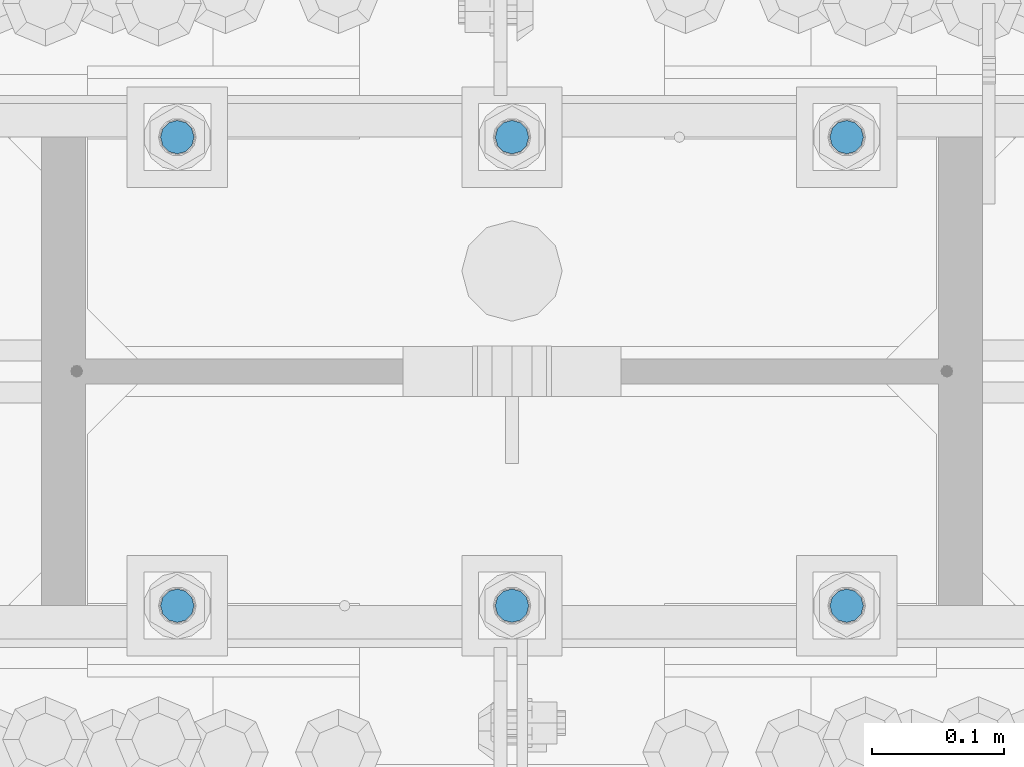
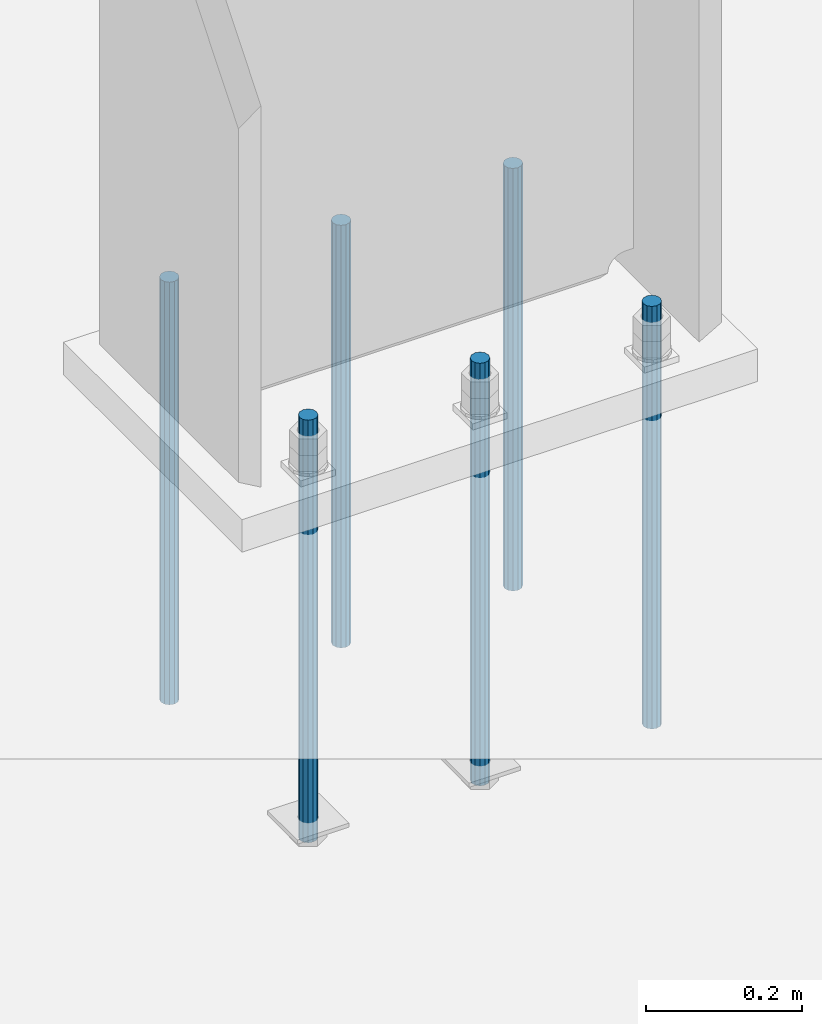
# One storey, part 952 of 1763: 6 columns, 1 element without a shape of its own.
"""IFC2X3 building model written with IfcOpenShell, lengths in millimetres."""

from ifc_helpers import new_model, si_unit, frame, origin_with_axes, place, context, subcontext, project, spatial, faceted_brep, material, type_object, element, aggregate, save


model = new_model("IFC2X3")

# Units and contexts
model_context = context("Model", 3, precision=1e-05, world=origin_with_axes())
body_context = subcontext(model_context, "Body", "Model", "MODEL_VIEW")
ifc_project = project(units=[si_unit("LENGTHUNIT", "METRE", prefix="MILLI"), si_unit("AREAUNIT", "SQUARE_METRE"), si_unit("VOLUMEUNIT", "CUBIC_METRE"), si_unit("MASSUNIT", "GRAM", prefix="KILO"), si_unit("TIMEUNIT", "SECOND"), si_unit("PLANEANGLEUNIT", "RADIAN"), si_unit("SOLIDANGLEUNIT", "STERADIAN"), si_unit("THERMODYNAMICTEMPERATUREUNIT", "DEGREE_CELSIUS"), si_unit("LUMINOUSINTENSITYUNIT", "LUMEN")], contexts=[model_context])

# Site, building, storey
site_placement = place(None, origin_with_axes())
site = spatial("IfcSite", under=ifc_project, at=site_placement, CompositionType="ELEMENT")
building_placement = place(site_placement, origin_with_axes())
building = spatial("IfcBuilding", under=site, at=building_placement, Name="Undefined", CompositionType="ELEMENT")
storey_placement = place(building_placement, origin_with_axes())
storey = spatial("IfcBuildingStorey", under=building, at=storey_placement, Name="Undefined", CompositionType="ELEMENT", Elevation=0.0)

# Assembly, columns
assembly_placement = place(storey_placement, origin_with_axes())
assembly = element("IfcElementAssembly", 1, at=assembly_placement, inside=storey, Name="TEMPLATE", AssemblyPlace="NOTDEFINED", PredefinedType="RIGID_FRAME")
ifc_material = material(Name="STEEL/F1554-55")
column_type = type_object("IfcColumnType", PredefinedType="NOTDEFINED")
column_1_placement = place(assembly_placement, frame((-72237.0372736984, 51943.0, -126.999999999999), z_axis=(1.0, 0.0, 0.0), x_axis=(0.0, 0.0, -1.0)))
column_1 = element("IfcColumn", 2, at=column_1_placement, type_object=column_type, material=ifc_material, Name="ALL THREADED ROD", context=body_context, shape_type="Brep", body=[
    faceted_brep([(0.0, -12.6999999999971, -1.81898940354586e-12), (0.0, -10.9985226280623, -6.35000000000582), (660.399, -10.9985226280623, -6.35000000000582), (660.399, -12.6999999999971, 0.0), (0.0, -6.34999999999854, -10.9985226280696), (660.399, -6.34999999999854, -10.9985226280696), (3.63797880709171e-12, 0.0, -12.6999998092651), (660.399, 0.0, -12.6999999999971), (0.0, 6.34999999999854, -10.9985226280696), (660.399, 6.34999999999854, -10.9985226280696), (0.0, 10.9985226280623, -6.35000000000582), (660.399, 10.9985226280623, -6.35000000000582), (0.0, 12.6999999999971, -1.81898940354586e-12), (660.399, 12.6999999999971, 0.0), (0.0, 10.9985226280623, 6.35000000000582), (660.399, 10.9985226280623, 6.35000000000582), (0.0, 6.34999999999854, 10.9985226280696), (660.399, 6.34999999999854, 10.9985226280696), (-3.63797880709171e-12, 0.0, 12.6999998092651), (660.399, 0.0, 12.6999999999971), (0.0, -6.34999999999854, 10.9985226280696), (660.399, -6.34999999999854, 10.9985226280696), (0.0, -10.9985226280623, 6.35000000000582), (660.399, -10.9985226280623, 6.35000000000582)], [[[0, 1, 2, 3]], [[1, 4, 5, 2]], [[4, 6, 7, 5]], [[6, 8, 9, 7]], [[8, 10, 11, 9]], [[10, 12, 13, 11]], [[12, 14, 15, 13]], [[14, 16, 17, 15]], [[16, 18, 19, 17]], [[18, 20, 21, 19]], [[20, 22, 23, 21]], [[22, 0, 3, 23]], [[5, 7, 9, 11, 13, 15, 17, 19, 21, 23, 3, 2]], [[22, 20, 18, 16, 14, 12, 10, 8, 6, 4, 1, 0]]]),
])
column_2_placement = place(assembly_placement, frame((-72237.0372736984, 52298.6, -126.999999999999), z_axis=(-1.0, 0.0, 0.0), x_axis=(0.0, 0.0, -1.0)))
column_2 = element("IfcColumn", 3, at=column_2_placement, type_object=column_type, material=ifc_material, Name="ALL THREADED ROD", context=body_context, shape_type="Brep", body=[
    faceted_brep([(0.0, -12.6999999999971, -1.81898940354586e-12), (0.0, -10.9985226280623, -6.35000000000582), (660.399, -10.9985226280623, -6.35000000000582), (660.399, -12.6999999999971, 0.0), (0.0, -6.34999999999854, -10.9985226280696), (660.399, -6.34999999999854, -10.9985226280696), (3.63797880709171e-12, 0.0, -12.6999998092651), (660.399, 0.0, -12.6999999999971), (0.0, 6.34999999999854, -10.9985226280696), (660.399, 6.34999999999854, -10.9985226280696), (0.0, 10.9985226280623, -6.35000000000582), (660.399, 10.9985226280623, -6.35000000000582), (0.0, 12.6999999999971, -1.81898940354586e-12), (660.399, 12.6999999999971, 0.0), (0.0, 10.9985226280623, 6.35000000000582), (660.399, 10.9985226280623, 6.35000000000582), (0.0, 6.34999999999854, 10.9985226280696), (660.399, 6.34999999999854, 10.9985226280696), (-3.63797880709171e-12, 0.0, 12.6999998092651), (660.399, 0.0, 12.6999999999971), (0.0, -6.34999999999854, 10.9985226280696), (660.399, -6.34999999999854, 10.9985226280696), (0.0, -10.9985226280623, 6.35000000000582), (660.399, -10.9985226280623, 6.35000000000582)], [[[0, 1, 2, 3]], [[1, 4, 5, 2]], [[4, 6, 7, 5]], [[6, 8, 9, 7]], [[8, 10, 11, 9]], [[10, 12, 13, 11]], [[12, 14, 15, 13]], [[14, 16, 17, 15]], [[16, 18, 19, 17]], [[18, 20, 21, 19]], [[20, 22, 23, 21]], [[22, 0, 3, 23]], [[5, 7, 9, 11, 13, 15, 17, 19, 21, 23, 3, 2]], [[22, 20, 18, 16, 14, 12, 10, 8, 6, 4, 1, 0]]]),
])
column_3_placement = place(assembly_placement, frame((-72491.0372736984, 51943.0, -126.999999999999), z_axis=(1.0, 0.0, 0.0), x_axis=(0.0, 0.0, -1.0)))
column_3 = element("IfcColumn", 4, at=column_3_placement, type_object=column_type, material=ifc_material, Name="ALL THREADED ROD", context=body_context, shape_type="Brep", body=[
    faceted_brep([(0.0, -12.6999999999971, -1.81898940354586e-12), (0.0, -10.9985226280623, -6.35000000000582), (660.399, -10.9985226280623, -6.35000000000582), (660.399, -12.6999999999971, 0.0), (0.0, -6.34999999999854, -10.9985226280696), (660.399, -6.34999999999854, -10.9985226280696), (3.63797880709171e-12, 0.0, -12.6999998092651), (660.399, 0.0, -12.6999999999971), (0.0, 6.34999999999854, -10.9985226280696), (660.399, 6.34999999999854, -10.9985226280696), (0.0, 10.9985226280623, -6.35000000000582), (660.399, 10.9985226280623, -6.35000000000582), (0.0, 12.6999999999971, -1.81898940354586e-12), (660.399, 12.6999999999971, 0.0), (0.0, 10.9985226280623, 6.35000000000582), (660.399, 10.9985226280623, 6.35000000000582), (0.0, 6.34999999999854, 10.9985226280696), (660.399, 6.34999999999854, 10.9985226280696), (-3.63797880709171e-12, 0.0, 12.6999998092651), (660.399, 0.0, 12.6999999999971), (0.0, -6.34999999999854, 10.9985226280696), (660.399, -6.34999999999854, 10.9985226280696), (0.0, -10.9985226280623, 6.35000000000582), (660.399, -10.9985226280623, 6.35000000000582)], [[[0, 1, 2, 3]], [[1, 4, 5, 2]], [[4, 6, 7, 5]], [[6, 8, 9, 7]], [[8, 10, 11, 9]], [[10, 12, 13, 11]], [[12, 14, 15, 13]], [[14, 16, 17, 15]], [[16, 18, 19, 17]], [[18, 20, 21, 19]], [[20, 22, 23, 21]], [[22, 0, 3, 23]], [[5, 7, 9, 11, 13, 15, 17, 19, 21, 23, 3, 2]], [[22, 20, 18, 16, 14, 12, 10, 8, 6, 4, 1, 0]]]),
])
column_4_placement = place(assembly_placement, frame((-72491.0372736984, 52298.6, -126.999999999999), z_axis=(-1.0, 0.0, 0.0), x_axis=(0.0, 0.0, -1.0)))
column_4 = element("IfcColumn", 5, at=column_4_placement, type_object=column_type, material=ifc_material, Name="ALL THREADED ROD", context=body_context, shape_type="Brep", body=[
    faceted_brep([(0.0, -12.6999999999971, -1.81898940354586e-12), (0.0, -10.9985226280623, -6.35000000000582), (660.399, -10.9985226280623, -6.35000000000582), (660.399, -12.6999999999971, 0.0), (0.0, -6.34999999999854, -10.9985226280696), (660.399, -6.34999999999854, -10.9985226280696), (3.63797880709171e-12, 0.0, -12.6999998092651), (660.399, 0.0, -12.6999999999971), (0.0, 6.34999999999854, -10.9985226280696), (660.399, 6.34999999999854, -10.9985226280696), (0.0, 10.9985226280623, -6.35000000000582), (660.399, 10.9985226280623, -6.35000000000582), (0.0, 12.6999999999971, -1.81898940354586e-12), (660.399, 12.6999999999971, 0.0), (0.0, 10.9985226280623, 6.35000000000582), (660.399, 10.9985226280623, 6.35000000000582), (0.0, 6.34999999999854, 10.9985226280696), (660.399, 6.34999999999854, 10.9985226280696), (-3.63797880709171e-12, 0.0, 12.6999998092651), (660.399, 0.0, 12.6999999999971), (0.0, -6.34999999999854, 10.9985226280696), (660.399, -6.34999999999854, 10.9985226280696), (0.0, -10.9985226280623, 6.35000000000582), (660.399, -10.9985226280623, 6.35000000000582)], [[[0, 1, 2, 3]], [[1, 4, 5, 2]], [[4, 6, 7, 5]], [[6, 8, 9, 7]], [[8, 10, 11, 9]], [[10, 12, 13, 11]], [[12, 14, 15, 13]], [[14, 16, 17, 15]], [[16, 18, 19, 17]], [[18, 20, 21, 19]], [[20, 22, 23, 21]], [[22, 0, 3, 23]], [[5, 7, 9, 11, 13, 15, 17, 19, 21, 23, 3, 2]], [[22, 20, 18, 16, 14, 12, 10, 8, 6, 4, 1, 0]]]),
])
column_5_placement = place(assembly_placement, frame((-72745.0372736984, 51943.0, -126.999999999999), z_axis=(1.0, 0.0, 0.0), x_axis=(0.0, 0.0, -1.0)))
column_5 = element("IfcColumn", 6, at=column_5_placement, type_object=column_type, material=ifc_material, Name="ALL THREADED ROD", context=body_context, shape_type="Brep", body=[
    faceted_brep([(0.0, -12.6999999999971, -1.81898940354586e-12), (0.0, -10.9985226280623, -6.35000000000582), (660.399, -10.9985226280623, -6.35000000000582), (660.399, -12.6999999999971, 0.0), (0.0, -6.34999999999854, -10.9985226280696), (660.399, -6.34999999999854, -10.9985226280696), (3.63797880709171e-12, 0.0, -12.6999998092651), (660.399, 0.0, -12.6999999999971), (0.0, 6.34999999999854, -10.9985226280696), (660.399, 6.34999999999854, -10.9985226280696), (0.0, 10.9985226280623, -6.35000000000582), (660.399, 10.9985226280623, -6.35000000000582), (0.0, 12.6999999999971, -1.81898940354586e-12), (660.399, 12.6999999999971, 0.0), (0.0, 10.9985226280623, 6.35000000000582), (660.399, 10.9985226280623, 6.35000000000582), (0.0, 6.34999999999854, 10.9985226280696), (660.399, 6.34999999999854, 10.9985226280696), (-3.63797880709171e-12, 0.0, 12.6999998092651), (660.399, 0.0, 12.6999999999971), (0.0, -6.34999999999854, 10.9985226280696), (660.399, -6.34999999999854, 10.9985226280696), (0.0, -10.9985226280623, 6.35000000000582), (660.399, -10.9985226280623, 6.35000000000582)], [[[0, 1, 2, 3]], [[1, 4, 5, 2]], [[4, 6, 7, 5]], [[6, 8, 9, 7]], [[8, 10, 11, 9]], [[10, 12, 13, 11]], [[12, 14, 15, 13]], [[14, 16, 17, 15]], [[16, 18, 19, 17]], [[18, 20, 21, 19]], [[20, 22, 23, 21]], [[22, 0, 3, 23]], [[5, 7, 9, 11, 13, 15, 17, 19, 21, 23, 3, 2]], [[22, 20, 18, 16, 14, 12, 10, 8, 6, 4, 1, 0]]]),
])
column_6_placement = place(assembly_placement, frame((-72745.0372736984, 52298.6, -126.999999999999), z_axis=(-1.0, 0.0, 0.0), x_axis=(0.0, 0.0, -1.0)))
column_6 = element("IfcColumn", 7, at=column_6_placement, type_object=column_type, material=ifc_material, Name="ALL THREADED ROD", context=body_context, shape_type="Brep", body=[
    faceted_brep([(0.0, -12.6999999999971, -1.81898940354586e-12), (0.0, -10.9985226280623, -6.35000000000582), (660.399, -10.9985226280623, -6.35000000000582), (660.399, -12.6999999999971, 0.0), (0.0, -6.34999999999854, -10.9985226280696), (660.399, -6.34999999999854, -10.9985226280696), (3.63797880709171e-12, 0.0, -12.6999998092651), (660.399, 0.0, -12.6999999999971), (0.0, 6.34999999999854, -10.9985226280696), (660.399, 6.34999999999854, -10.9985226280696), (0.0, 10.9985226280623, -6.35000000000582), (660.399, 10.9985226280623, -6.35000000000582), (0.0, 12.6999999999971, -1.81898940354586e-12), (660.399, 12.6999999999971, 0.0), (0.0, 10.9985226280623, 6.35000000000582), (660.399, 10.9985226280623, 6.35000000000582), (0.0, 6.34999999999854, 10.9985226280696), (660.399, 6.34999999999854, 10.9985226280696), (-3.63797880709171e-12, 0.0, 12.6999998092651), (660.399, 0.0, 12.6999999999971), (0.0, -6.34999999999854, 10.9985226280696), (660.399, -6.34999999999854, 10.9985226280696), (0.0, -10.9985226280623, 6.35000000000582), (660.399, -10.9985226280623, 6.35000000000582)], [[[0, 1, 2, 3]], [[1, 4, 5, 2]], [[4, 6, 7, 5]], [[6, 8, 9, 7]], [[8, 10, 11, 9]], [[10, 12, 13, 11]], [[12, 14, 15, 13]], [[14, 16, 17, 15]], [[16, 18, 19, 17]], [[18, 20, 21, 19]], [[20, 22, 23, 21]], [[22, 0, 3, 23]], [[5, 7, 9, 11, 13, 15, 17, 19, 21, 23, 3, 2]], [[22, 20, 18, 16, 14, 12, 10, 8, 6, 4, 1, 0]]]),
])
aggregate(assembly, [column_1, column_2, column_3, column_4, column_5, column_6])

save(model, "model.ifc")
